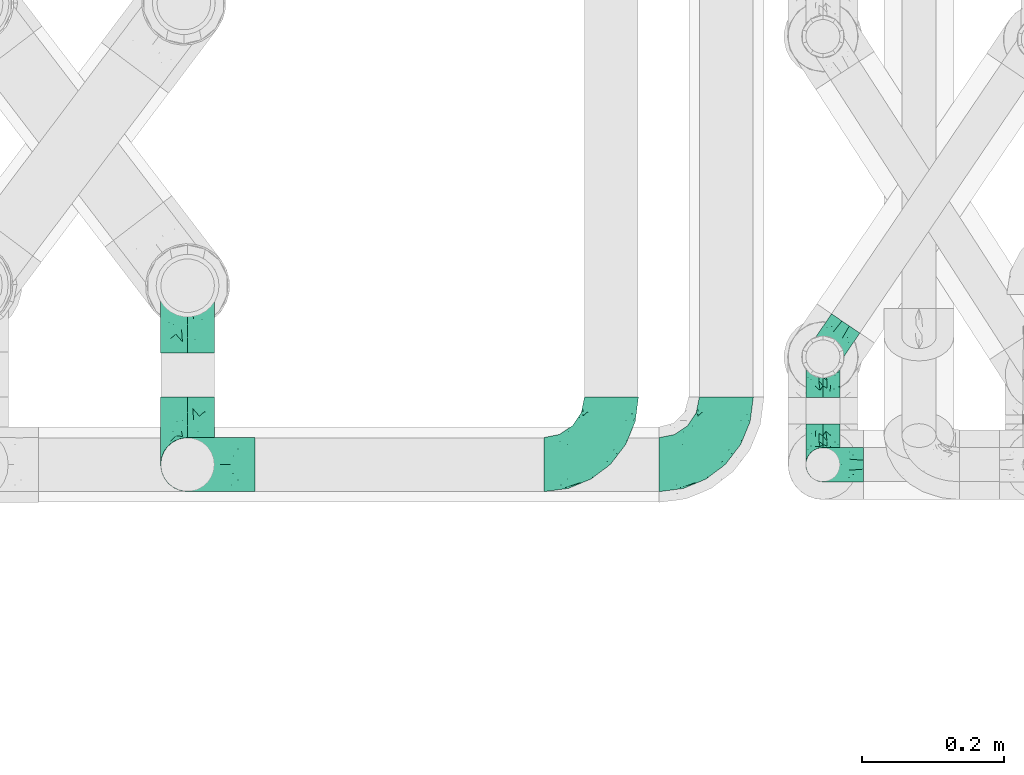
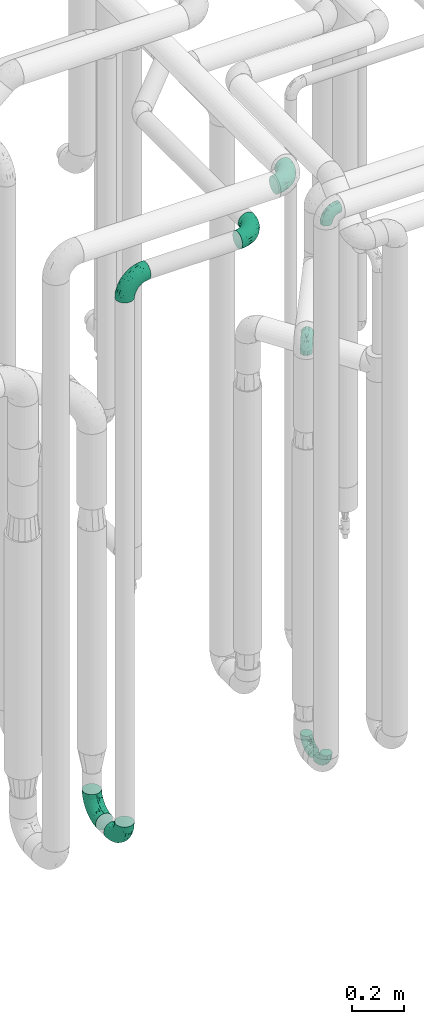
# One storey, part 660 of 827: 9 flow fittings.
"""IFC2X3 building model written with IfcOpenShell, lengths in millimetres."""

from ifc_helpers import new_model, entity, si_unit, converted_unit, derived_unit, direction, frame, origin, place, context, subcontext, project, spatial, faceted_brep, source, transform, mapped, material, type_object, type_shapes, element, save


model = new_model("IFC2X3")

# Units and contexts
model_context = context("Model", 3, precision=0.01, world=origin(), true_north=direction((6.12303176911189e-17, 1.0)))
body_context = subcontext(model_context, "Body", "Model", "MODEL_VIEW")
ifc_project = project(units=[si_unit("LENGTHUNIT", "METRE", prefix="MILLI"), si_unit("AREAUNIT", "SQUARE_METRE"), si_unit("VOLUMEUNIT", "CUBIC_METRE"), converted_unit("PLANEANGLEUNIT", "DEGREE", entity("IfcRatioMeasure", 0.0174532925199433), si_unit("PLANEANGLEUNIT", "RADIAN"), dimensions=[0, 0, 0, 0, 0, 0, 0]), si_unit("MASSUNIT", "GRAM", prefix="KILO"), derived_unit("MASSDENSITYUNIT", [(si_unit("MASSUNIT", "GRAM", prefix="KILO"), 1), (si_unit("LENGTHUNIT", "METRE"), -3)]), derived_unit("MOMENTOFINERTIAUNIT", [(si_unit("LENGTHUNIT", "METRE"), 4)]), si_unit("TIMEUNIT", "SECOND"), si_unit("FREQUENCYUNIT", "HERTZ"), si_unit("THERMODYNAMICTEMPERATUREUNIT", "DEGREE_CELSIUS"), derived_unit("THERMALTRANSMITTANCEUNIT", [(si_unit("MASSUNIT", "GRAM", prefix="KILO"), 1), (si_unit("THERMODYNAMICTEMPERATUREUNIT", "KELVIN"), -1), (si_unit("TIMEUNIT", "SECOND"), -3)]), derived_unit("VOLUMETRICFLOWRATEUNIT", [(si_unit("LENGTHUNIT", "METRE"), 3), (si_unit("TIMEUNIT", "SECOND"), -1)]), derived_unit("MASSFLOWRATEUNIT", [(si_unit("MASSUNIT", "GRAM", prefix="KILO"), 1), (si_unit("TIMEUNIT", "SECOND"), -1)]), derived_unit("ROTATIONALFREQUENCYUNIT", [(si_unit("TIMEUNIT", "SECOND"), -1)]), si_unit("ELECTRICCURRENTUNIT", "AMPERE"), si_unit("ELECTRICVOLTAGEUNIT", "VOLT"), si_unit("POWERUNIT", "WATT"), si_unit("FORCEUNIT", "NEWTON", prefix="KILO"), si_unit("ILLUMINANCEUNIT", "LUX"), si_unit("LUMINOUSFLUXUNIT", "LUMEN"), si_unit("LUMINOUSINTENSITYUNIT", "CANDELA"), derived_unit("USERDEFINED", [(si_unit("MASSUNIT", "GRAM", prefix="KILO"), -1), (si_unit("LENGTHUNIT", "METRE"), -2), (si_unit("TIMEUNIT", "SECOND"), 3), (si_unit("LUMINOUSFLUXUNIT", "LUMEN"), 1)]), derived_unit("LINEARVELOCITYUNIT", [(si_unit("LENGTHUNIT", "METRE"), 1), (si_unit("TIMEUNIT", "SECOND"), -1)]), si_unit("PRESSUREUNIT", "PASCAL"), derived_unit("USERDEFINED", [(si_unit("LENGTHUNIT", "METRE"), -2), (si_unit("MASSUNIT", "GRAM", prefix="KILO"), 1), (si_unit("TIMEUNIT", "SECOND"), -2)]), derived_unit("LINEARFORCEUNIT", [(si_unit("MASSUNIT", "GRAM", prefix="KILO"), 1), (si_unit("LENGTHUNIT", "METRE"), 1), (si_unit("TIMEUNIT", "SECOND"), -2), (si_unit("LENGTHUNIT", "METRE"), -1)]), derived_unit("PLANARFORCEUNIT", [(si_unit("MASSUNIT", "GRAM", prefix="KILO"), 1), (si_unit("LENGTHUNIT", "METRE"), 1), (si_unit("TIMEUNIT", "SECOND"), -2), (si_unit("LENGTHUNIT", "METRE"), -2)])], contexts=[model_context])

# Site, building, storey
site_placement = place(None, origin())
site = spatial("IfcSite", under=ifc_project, at=site_placement, CompositionType="ELEMENT")
building_placement = place(site_placement, origin())
building = spatial("IfcBuilding", under=site, at=building_placement, CompositionType="ELEMENT")
storey_placement = place(building_placement, frame((0.0, 0.0, 28200.0)))
storey = spatial("IfcBuildingStorey", under=building, at=storey_placement, Name="08", CompositionType="ELEMENT", Elevation=28200.0)

# Flow fittings
ifc_material = material()
pipe_fitting_type_1 = type_object("IfcPipeFittingType", Name="ADSK_1", PredefinedType="NOTDEFINED", material=ifc_material)
shared_shape_1 = source(origin(), body_context, "Body", "Brep", [
    faceted_brep([(-57.0, 12.07, -20.91), (-57.0, 6.25, -23.33), (-57.0, 0.0, -24.15), (-57.0, -6.25, -23.33), (-57.0, -12.08, -20.91), (-57.0, -17.08, -17.08), (-57.0, -20.91, -12.08), (-57.0, -23.33, -6.25), (-57.0, -24.15, 0.0), (-57.0, -23.33, 6.25), (-57.0, -20.91, 12.07), (-57.0, -17.08, 17.08), (-57.0, -12.08, 20.91), (-57.0, -6.25, 23.33), (-57.0, 0.0, 24.15), (-57.0, 6.25, 23.33), (-57.0, 12.07, 20.91), (-57.0, 17.08, 17.08), (-57.0, 20.91, 12.07), (-57.0, 23.33, 6.25), (-57.0, 24.15, 0.0), (-57.0, 23.33, -6.25), (-57.0, 20.91, -12.08), (-57.0, 17.08, -17.08), (0.0, 57.0, -24.15), (-6.25, 57.0, -23.33), (-12.07, 57.0, -20.91), (-17.08, 57.0, -17.08), (-20.91, 57.0, -12.08), (-23.33, 57.0, -6.25), (-24.15, 57.0, 0.0), (-23.33, 57.0, 6.25), (-20.91, 57.0, 12.07), (-17.08, 57.0, 17.08), (-12.07, 57.0, 20.91), (-6.25, 57.0, 23.33), (0.0, 57.0, 24.15), (6.25, 57.0, 23.33), (12.08, 57.0, 20.91), (17.08, 57.0, 17.08), (20.91, 57.0, 12.07), (23.33, 57.0, 6.25), (24.15, 57.0, 0.0), (23.33, 57.0, -6.25), (20.91, 57.0, -12.08), (17.08, 57.0, -17.08), (12.08, 57.0, -20.91), (6.25, 57.0, -23.33), (14.9, 21.14, 6.17), (13.61, 24.64, 12.48), (6.23, 8.95, 8.98), (-41.47, -21.06, 0.0), (-41.92, -18.38, 13.72), (-24.64, -13.61, 12.48), (-37.37, -13.24, 18.15), (-6.8, -4.93, 8.18), (-21.76, -15.19, 6.22), (-12.78, -9.18, 0.0), (-37.73, -20.51, 7.75), (-7.38, 7.38, 20.24), (-23.37, -4.26, 20.42), (-11.9, -3.19, 15.86), (-42.14, -8.7, 21.82), (13.24, 37.37, 18.15), (9.33, 23.53, 16.85), (4.26, 23.37, 20.42), (2.77, 10.92, 15.55), (-29.46, 0.91, 23.52), (-44.13, 20.56, 15.69), (-39.25, 26.33, 10.88), (-49.02, 22.92, 9.96), (-34.58, 23.87, 17.15), (-15.8, 6.8, 22.81), (-8.67, 20.47, 23.88), (-18.12, 12.9, 24.08), (-48.29, 14.92, 19.65), (-44.06, -2.85, 23.78), (-9.23, 48.95, 22.58), (-3.78, 42.74, 24.07), (-40.34, 4.26, 24.09), (-44.02, 26.14, 5.46), (-44.04, 9.88, 22.74), (-4.95, 16.87, 22.52), (-2.75, 1.43, 12.5), (-25.48, 40.98, 10.71), (20.51, 37.73, 7.75), (18.38, 41.92, 13.72), (8.7, 42.14, 21.82), (-25.95, -17.97, 0.0), (2.85, 44.06, 23.78), (21.06, 41.47, 0.0), (17.97, 25.95, 0.0), (-24.04, -9.27, 17.13), (-33.26, 33.26, 5.86), (-28.55, 40.57, 0.0), (-40.57, 28.55, 0.0), (-25.29, 47.19, 4.06), (-27.01, 31.1, 16.77), (-15.7, 43.95, 19.9), (-20.27, 45.22, 15.61), (-30.53, 31.98, 12.64), (-11.28, 38.33, 22.92), (-9.97, 27.88, 24.09), (-20.15, 30.26, 21.25), (-31.25, 11.75, 23.64), (-28.75, 7.23, 24.15), (-29.53, 18.06, 22.27), (-28.44, 24.21, 20.02), (-37.55, 17.7, 20.26), (-15.88, 29.25, 22.99), (-20.82, 20.82, 23.44), (-0.91, 29.46, 23.52), (-13.5, -7.67, 12.04), (1.49, 1.56, 5.16), (8.86, 10.35, 4.59), (0.38, -0.38, 0.0), (9.18, 12.78, 0.0), (-37.37, -13.24, -18.15), (8.86, 10.35, -4.59), (-45.22, 20.27, -15.61), (-43.95, 15.7, -19.9), (-38.33, 11.28, -22.92), (-48.95, 9.23, -22.58), (-47.19, 25.29, -4.06), (-33.26, 33.26, -5.86), (18.38, 41.92, -13.72), (-30.26, 20.15, -21.25), (2.85, 44.06, -23.78), (-4.26, 40.34, -24.09), (-40.98, 25.48, -10.71), (-41.92, -18.38, -13.72), (9.25, 23.5, -16.92), (4.26, 23.37, -20.42), (13.24, 37.37, -18.15), (-37.73, -20.51, -7.75), (-11.75, 31.25, -23.64), (-7.23, 28.75, -24.15), (-12.9, 18.12, -24.08), (8.7, 42.14, -21.82), (-44.06, -2.85, -23.78), (-6.8, 15.8, -22.81), (-20.47, 8.67, -23.88), (-24.64, -13.61, -12.48), (-42.74, 3.78, -24.07), (-18.06, 29.53, -22.27), (-24.21, 28.44, -20.02), (-27.88, 9.97, -24.09), (-31.1, 27.01, -16.77), (-26.14, 44.02, -5.46), (14.9, 21.14, -6.17), (20.51, 37.73, -7.75), (-9.88, 44.04, -22.74), (-20.56, 44.13, -15.69), (-21.76, -15.19, -6.22), (-13.5, -7.67, -12.04), (-24.14, -9.76, -16.74), (-11.9, -3.19, -15.86), (-14.92, 48.29, -19.65), (-23.37, -4.26, -20.42), (-0.91, 29.46, -23.52), (-26.33, 39.25, -10.88), (-23.87, 34.58, -17.15), (-42.14, -8.7, -21.82), (-22.92, 49.02, -9.96), (13.61, 24.64, -12.48), (-31.98, 30.53, -12.64), (-16.87, 4.95, -22.52), (-17.7, 37.55, -20.26), (-29.25, 15.88, -22.99), (-20.82, 20.82, -23.44), (-29.46, 0.91, -23.52), (-7.38, 7.38, -20.24), (2.77, 10.92, -15.55), (6.23, 8.95, -8.98), (-6.8, -4.93, -8.18), (-2.81, 1.41, -12.54), (1.49, 1.56, -5.16)], [[[0, 1, 2, 3, 4, 5, 6, 7, 8, 9, 10, 11, 12, 13, 14, 15, 16, 17, 18, 19, 20, 21, 22, 23]], [[24, 25, 26, 27, 28, 29, 30, 31, 32, 33, 34, 35, 36, 37, 38, 39, 40, 41, 42, 43, 44, 45, 46, 47]], [[48, 49, 50]], [[9, 8, 51]], [[52, 53, 54]], [[55, 56, 57]], [[10, 58, 52]], [[9, 58, 10]], [[59, 60, 61]], [[54, 12, 11]], [[54, 62, 12]], [[63, 39, 38]], [[64, 65, 66]], [[62, 60, 67]], [[68, 69, 70]], [[71, 69, 68]], [[72, 73, 74]], [[16, 75, 17]], [[13, 76, 14]], [[35, 77, 78]], [[14, 79, 15]], [[17, 68, 18]], [[14, 76, 79]], [[20, 19, 80]], [[70, 19, 18]], [[81, 15, 79]], [[15, 81, 16]], [[73, 72, 82]], [[66, 83, 50]], [[32, 31, 84]], [[85, 86, 49]], [[63, 87, 65]], [[56, 58, 88]], [[36, 89, 37]], [[85, 41, 40]], [[36, 35, 78]], [[90, 41, 85]], [[40, 39, 86]], [[12, 62, 13]], [[86, 85, 40]], [[48, 85, 49]], [[85, 91, 90]], [[87, 38, 37]], [[92, 60, 54]], [[80, 69, 93]], [[93, 94, 95]], [[10, 52, 11]], [[94, 96, 30]], [[97, 98, 99]], [[80, 93, 95]], [[100, 97, 84]], [[99, 98, 33]], [[101, 102, 78]], [[103, 101, 98]], [[96, 31, 30]], [[77, 98, 101]], [[77, 35, 34]], [[34, 33, 98]], [[9, 51, 58]], [[87, 63, 38]], [[104, 105, 74]], [[106, 103, 107]], [[106, 81, 104]], [[75, 68, 17]], [[108, 107, 71]], [[33, 32, 99]], [[109, 103, 110]], [[101, 109, 102]], [[89, 78, 111]], [[53, 52, 58]], [[54, 11, 52]], [[60, 62, 54]], [[88, 58, 51]], [[76, 62, 67]], [[53, 112, 92]], [[60, 59, 72]], [[39, 63, 86]], [[49, 86, 63]], [[89, 87, 37]], [[42, 41, 90]], [[111, 82, 65]], [[111, 65, 87]], [[65, 59, 66]], [[104, 81, 79]], [[75, 81, 108]], [[32, 84, 99]], [[97, 99, 84]], [[98, 97, 103]], [[106, 107, 108]], [[74, 102, 110]], [[111, 78, 102]], [[74, 110, 104]], [[74, 67, 72]], [[61, 92, 112]], [[66, 59, 61]], [[56, 53, 58]], [[66, 50, 49]], [[61, 112, 83]], [[66, 49, 64]], [[78, 89, 36]], [[87, 89, 111]], [[62, 76, 13]], [[79, 76, 67]], [[100, 93, 69]], [[96, 93, 84]], [[55, 113, 50]], [[113, 114, 50]], [[104, 79, 105]], [[106, 104, 110]], [[20, 80, 95]], [[85, 48, 91]], [[115, 114, 113]], [[116, 91, 48]], [[70, 80, 19]], [[93, 96, 94]], [[84, 31, 96]], [[103, 106, 110]], [[81, 106, 108]], [[103, 97, 107]], [[71, 107, 97]], [[71, 97, 100]], [[108, 71, 68]], [[79, 67, 105]], [[67, 74, 105]], [[115, 113, 57]], [[112, 56, 55]], [[56, 88, 57]], [[60, 72, 67]], [[82, 72, 59]], [[65, 82, 59]], [[82, 111, 73]], [[111, 102, 73]], [[102, 74, 73]], [[81, 75, 16]], [[68, 75, 108]], [[68, 70, 18]], [[80, 70, 69]], [[98, 77, 34]], [[78, 77, 101]], [[93, 100, 84]], [[71, 100, 69]], [[102, 109, 110]], [[101, 103, 109]], [[53, 92, 54]], [[61, 60, 92]], [[56, 112, 53]], [[83, 112, 55]], [[50, 83, 55]], [[61, 83, 66]], [[49, 63, 64]], [[65, 64, 63]], [[57, 113, 55]], [[114, 115, 116]], [[116, 48, 114]], [[48, 50, 114]], [[117, 5, 4]], [[116, 115, 118]], [[119, 120, 23]], [[121, 122, 120]], [[95, 123, 20]], [[0, 23, 120]], [[124, 95, 94]], [[125, 45, 44]], [[121, 120, 126]], [[24, 127, 128]], [[22, 21, 129]], [[0, 122, 1]], [[5, 117, 130]], [[131, 132, 133]], [[134, 88, 51]], [[135, 136, 137]], [[6, 5, 130]], [[46, 138, 47]], [[139, 3, 2]], [[140, 141, 137]], [[6, 134, 7]], [[134, 130, 142]], [[143, 2, 1]], [[144, 126, 145]], [[121, 146, 143]], [[147, 120, 119]], [[94, 148, 124]], [[149, 150, 91]], [[30, 29, 148]], [[151, 25, 128]], [[27, 152, 28]], [[134, 153, 88]], [[154, 155, 156]], [[27, 26, 157]], [[151, 26, 25]], [[155, 158, 156]], [[24, 47, 127]], [[1, 122, 143]], [[138, 132, 159]], [[160, 152, 161]], [[24, 128, 25]], [[46, 133, 138]], [[162, 117, 4]], [[148, 160, 124]], [[152, 160, 163]], [[154, 142, 155]], [[45, 125, 133]], [[133, 46, 45]], [[125, 164, 133]], [[51, 7, 134]], [[42, 90, 43]], [[165, 147, 129]], [[153, 134, 142]], [[43, 150, 44]], [[162, 4, 3]], [[141, 140, 166]], [[117, 162, 158]], [[163, 29, 28]], [[43, 90, 150]], [[123, 21, 20]], [[144, 151, 135]], [[157, 152, 27]], [[167, 145, 161]], [[23, 22, 119]], [[168, 126, 169]], [[121, 168, 146]], [[139, 143, 170]], [[142, 130, 117]], [[8, 7, 51]], [[134, 6, 130]], [[139, 162, 3]], [[170, 166, 158]], [[170, 158, 162]], [[158, 171, 156]], [[44, 150, 125]], [[91, 150, 90]], [[164, 125, 150]], [[132, 138, 133]], [[127, 138, 159]], [[131, 164, 172]], [[132, 171, 140]], [[135, 151, 128]], [[157, 151, 167]], [[22, 129, 119]], [[147, 119, 129]], [[120, 147, 126]], [[144, 145, 167]], [[137, 146, 169]], [[170, 143, 146]], [[137, 169, 135]], [[137, 159, 140]], [[171, 172, 156]], [[173, 174, 175]], [[156, 175, 154]], [[174, 57, 153]], [[132, 172, 171]], [[172, 164, 173]], [[143, 139, 2]], [[162, 139, 170]], [[138, 127, 47]], [[128, 127, 159]], [[165, 124, 160]], [[123, 124, 129]], [[149, 173, 164]], [[176, 174, 173]], [[135, 128, 136]], [[144, 135, 169]], [[150, 149, 164]], [[176, 118, 115]], [[149, 91, 116]], [[30, 148, 94]], [[163, 148, 29]], [[124, 123, 95]], [[129, 21, 123]], [[126, 144, 169]], [[151, 144, 167]], [[126, 147, 145]], [[161, 145, 147]], [[161, 147, 165]], [[167, 161, 152]], [[128, 159, 136]], [[159, 137, 136]], [[154, 153, 142]], [[132, 140, 159]], [[174, 176, 57]], [[57, 88, 153]], [[166, 140, 171]], [[158, 166, 171]], [[166, 170, 141]], [[170, 146, 141]], [[146, 137, 141]], [[151, 157, 26]], [[152, 157, 167]], [[152, 163, 28]], [[148, 163, 160]], [[120, 122, 0]], [[143, 122, 121]], [[124, 165, 129]], [[161, 165, 160]], [[146, 168, 169]], [[121, 126, 168]], [[142, 117, 155]], [[158, 155, 117]], [[175, 156, 172]], [[153, 154, 174]], [[173, 175, 172]], [[174, 154, 175]], [[164, 131, 133]], [[172, 132, 131]], [[176, 173, 118]], [[57, 176, 115]], [[173, 149, 118]], [[149, 116, 118]]]),
])
type_shapes(pipe_fitting_type_1, [shared_shape_1])
for number, where, z_axis, x_axis, name in (
    (1, (46692.79, 13788.51, 400.0), (1.0, 0.0, 0.0), (0.0, 1.0, 0.0), "ADSK_1"),
    (2, (46692.79, 13636.84, 3000.0), (0.0, -1.0, 0.0), (-1.0, 0.0, 0.0), "ADSK_1"),
    (3, (46692.79, 13636.84, 400.0), (-1.0, 0.0, 0.0), (0.0, -1.0, 0.0), "ADSK_1"),
    (4, (46692.79, 13788.51, 2300.0), (-0.827641016663895, 0.561257826257732, 0.0), (0.0, 0.0, 1.0), "ADSK_1"),
):
    element("IfcFlowFitting", number, at=place(storey_placement, frame(where, z_axis=z_axis, x_axis=x_axis)), inside=storey, type_object=pipe_fitting_type_1, material=ifc_material, Name=name, ObjectType="ADSK_1", context=body_context, shape_type="MappedRepresentation", body=[
        mapped(shared_shape_1, transform((0.0, 0.0, 0.0), scale=1.0)),
    ])
pipe_fitting_type_2 = type_object("IfcPipeFittingType", Name="ADSK_1", PredefinedType="NOTDEFINED", material=ifc_material)
shared_shape_2 = source(origin(), body_context, "Body", "Brep", [
    faceted_brep([(-95.0, 19.02, -32.95), (-95.0, 9.85, -36.75), (-95.0, 0.0, -38.05), (-95.0, -9.85, -36.75), (-95.0, -19.03, -32.95), (-95.0, -26.91, -26.91), (-95.0, -32.95, -19.03), (-95.0, -36.75, -9.85), (-95.0, -38.05, 0.0), (-95.0, -36.75, 9.85), (-95.0, -32.95, 19.02), (-95.0, -26.91, 26.91), (-95.0, -19.03, 32.95), (-95.0, -9.85, 36.75), (-95.0, 0.0, 38.05), (-95.0, 9.85, 36.75), (-95.0, 19.02, 32.95), (-95.0, 26.91, 26.91), (-95.0, 32.95, 19.02), (-95.0, 36.75, 9.85), (-95.0, 38.05, 0.0), (-95.0, 36.75, -9.85), (-95.0, 32.95, -19.03), (-95.0, 26.91, -26.91), (0.0, 95.0, -38.05), (-9.85, 95.0, -36.75), (-19.02, 95.0, -32.95), (-26.91, 95.0, -26.91), (-32.95, 95.0, -19.03), (-36.75, 95.0, -9.85), (-38.05, 95.0, 0.0), (-36.75, 95.0, 9.85), (-32.95, 95.0, 19.02), (-26.91, 95.0, 26.91), (-19.02, 95.0, 32.95), (-9.85, 95.0, 36.75), (0.0, 95.0, 38.05), (9.85, 95.0, 36.75), (19.03, 95.0, 32.95), (26.91, 95.0, 26.91), (32.95, 95.0, 19.02), (36.75, 95.0, 9.85), (38.05, 95.0, 0.0), (36.75, 95.0, -9.85), (32.95, 95.0, -19.03), (26.91, 95.0, -26.91), (19.03, 95.0, -32.95), (9.85, 95.0, -36.75), (-7.99, -4.96, 6.3), (-0.92, 0.92, 0.0), (4.62, 8.1, 8.01), (-76.19, -35.57, 0.0), (-64.32, -32.32, 12.43), (20.51, 62.45, 28.68), (-60.56, -33.52, 0.0), (-70.4, -13.47, 34.42), (-39.61, -5.88, 32.32), (-49.6, 2.07, 37.1), (-70.34, -28.81, 21.71), (14.64, 40.81, 26.5), (5.88, 39.61, 32.32), (3.59, 20.77, 25.31), (-40.45, 68.06, 16.75), (-62.45, -20.51, 28.68), (-44.52, -26.87, 0.0), (-28.47, -20.22, 0.0), (-26.43, -17.83, 8.75), (-76.1, 39.63, 10.76), (-72.74, 37.58, 18.19), (-60.35, 46.18, 14.61), (-13.4, 13.4, 32.12), (-20.77, -3.59, 25.31), (-14.66, 81.47, 35.56), (-6.22, 71.26, 37.92), (-57.5, 42.48, 22.79), (-15.0, 34.74, 37.7), (-27.1, 12.08, 36.05), (-9.2, 28.81, 35.63), (-79.98, 23.7, 30.95), (-73.68, -4.3, 37.48), (-30.74, 21.67, 37.97), (-62.36, 47.59, 6.79), (-72.71, 32.83, 24.69), (-67.42, 7.02, 37.95), (-32.13, 75.27, 24.51), (-43.46, 51.47, 26.26), (-24.98, 73.15, 31.29), (20.59, 41.28, 19.85), (7.79, 16.09, 15.86), (-73.21, 42.39, 0.0), (-54.73, 54.73, 0.0), (-73.44, 15.79, 35.79), (-5.94, 4.32, 20.43), (28.81, 70.34, 21.71), (32.32, 64.32, 12.43), (-53.59, 26.2, 35.09), (-52.02, 19.31, 37.21), (21.38, 33.53, 10.34), (26.87, 44.52, 0.0), (-48.28, 12.14, 38.05), (4.3, 73.68, 37.48), (-44.08, -25.52, 12.79), (-41.28, -20.59, 19.85), (35.57, 76.19, 0.0), (-47.26, 54.3, 20.18), (-47.4, 61.99, 8.58), (-42.39, 73.21, 0.0), (-39.67, 78.86, 7.21), (-45.69, 36.84, 33.11), (-32.83, 50.13, 33.35), (13.47, 70.4, 34.42), (-18.25, 63.73, 36.07), (-40.63, -13.75, 27.22), (-16.63, 46.37, 37.95), (-53.47, 38.79, 28.59), (-26.07, 48.54, 36.15), (-34.51, 34.51, 36.86), (-2.07, 49.6, 37.1), (-22.79, -10.49, 19.23), (-61.73, 28.67, 31.87), (9.65, 14.7, 0.0), (20.22, 28.47, 0.0), (33.52, 60.56, 0.0), (-11.42, -5.44, 13.25), (-14.7, -9.65, 0.0), (-81.47, 14.66, -35.56), (-62.45, -20.51, -28.68), (-71.26, 6.22, -37.92), (-75.27, 32.13, -24.51), (-73.15, 24.98, -31.29), (13.47, 70.4, -34.42), (5.88, 39.61, -32.32), (-2.07, 49.6, -37.1), (-78.86, 39.67, -7.21), (-70.4, -13.47, -34.42), (-39.61, -5.88, -32.32), (-61.99, 47.4, -8.58), (32.32, 64.32, -12.43), (28.81, 70.34, -21.71), (-63.73, 18.25, -36.07), (-50.13, 32.83, -33.35), (4.3, 73.68, -37.48), (-7.02, 67.42, -37.95), (-39.63, 76.1, -10.76), (-46.18, 60.35, -14.61), (-47.59, 62.36, -6.79), (-64.32, -32.32, -12.43), (-26.2, 53.59, -35.09), (-15.79, 73.44, -35.79), (-19.31, 52.02, -37.21), (-37.58, 72.74, -18.19), (-70.34, -28.81, -21.71), (-42.48, 57.5, -22.79), (-38.79, 53.47, -28.59), (-51.47, 43.46, -26.26), (-32.83, 72.71, -24.69), (-46.37, 16.63, -37.95), (-73.68, -4.3, -37.48), (-41.28, -20.59, -19.85), (-44.08, -25.52, -12.79), (13.75, 40.63, -27.22), (20.51, 62.45, -28.68), (-68.06, 40.45, -16.75), (-54.3, 47.26, -20.18), (-12.14, 48.28, -38.05), (-21.67, 30.74, -37.97), (-36.84, 45.69, -33.11), (-11.42, -5.44, -13.25), (7.79, 16.09, -15.86), (4.62, 8.1, -8.01), (-23.7, 79.98, -30.95), (-26.43, -17.83, -8.75), (-7.99, -4.96, -6.3), (-40.81, -14.64, -26.5), (-20.77, -3.59, -25.31), (-34.74, 15.0, -37.7), (-12.08, 27.1, -36.05), (-28.81, 9.2, -35.63), (-22.79, -10.49, -19.23), (21.38, 33.53, -10.34), (20.59, 41.28, -19.85), (-48.54, 26.07, -36.15), (-49.6, 2.07, -37.1), (-13.4, 13.4, -32.12), (3.59, 20.77, -25.31), (-28.67, 61.73, -31.87), (-34.51, 34.51, -36.86), (-5.94, 4.32, -20.43)], [[[0, 1, 2, 3, 4, 5, 6, 7, 8, 9, 10, 11, 12, 13, 14, 15, 16, 17, 18, 19, 20, 21, 22, 23]], [[24, 25, 26, 27, 28, 29, 30, 31, 32, 33, 34, 35, 36, 37, 38, 39, 40, 41, 42, 43, 44, 45, 46, 47]], [[48, 49, 50]], [[51, 52, 9]], [[53, 39, 38]], [[9, 52, 10]], [[54, 52, 51]], [[55, 56, 57]], [[11, 10, 58]], [[59, 60, 61]], [[32, 31, 62]], [[63, 12, 11]], [[63, 55, 12]], [[64, 65, 66]], [[67, 68, 69]], [[70, 56, 71]], [[35, 72, 73]], [[69, 68, 74]], [[75, 76, 77]], [[16, 78, 17]], [[13, 79, 14]], [[76, 75, 80]], [[67, 69, 81]], [[18, 17, 82]], [[14, 79, 83]], [[20, 19, 67]], [[84, 85, 86]], [[87, 61, 88]], [[89, 81, 90]], [[18, 82, 68]], [[15, 91, 16]], [[14, 83, 15]], [[71, 92, 61]], [[17, 78, 82]], [[93, 87, 94]], [[95, 91, 96]], [[97, 98, 94]], [[86, 72, 34]], [[96, 99, 80]], [[37, 36, 100]], [[40, 39, 93]], [[40, 94, 41]], [[64, 66, 101]], [[93, 94, 40]], [[58, 102, 63]], [[94, 103, 41]], [[94, 87, 97]], [[104, 69, 74]], [[34, 33, 86]], [[105, 69, 104]], [[52, 58, 10]], [[106, 107, 30]], [[108, 109, 85]], [[105, 106, 90]], [[53, 110, 60]], [[86, 111, 72]], [[86, 109, 111]], [[33, 84, 86]], [[12, 55, 13]], [[112, 56, 63]], [[110, 38, 37]], [[34, 72, 35]], [[36, 35, 73]], [[111, 113, 73]], [[105, 107, 106]], [[110, 53, 38]], [[74, 114, 85]], [[91, 15, 83]], [[105, 90, 81]], [[107, 62, 31]], [[33, 32, 84]], [[115, 109, 116]], [[111, 115, 113]], [[100, 73, 117]], [[56, 55, 63]], [[79, 55, 57]], [[102, 118, 112]], [[56, 70, 76]], [[100, 110, 37]], [[117, 77, 60]], [[117, 60, 110]], [[60, 70, 61]], [[58, 52, 101]], [[63, 11, 58]], [[39, 53, 93]], [[87, 93, 53]], [[96, 91, 83]], [[78, 91, 119]], [[32, 62, 84]], [[84, 62, 104]], [[86, 85, 109]], [[85, 114, 108]], [[80, 113, 116]], [[117, 73, 113]], [[80, 116, 96]], [[80, 57, 76]], [[71, 112, 118]], [[61, 87, 59]], [[62, 107, 105]], [[97, 120, 121]], [[70, 71, 61]], [[71, 118, 92]], [[73, 100, 36]], [[110, 100, 117]], [[55, 79, 13]], [[83, 79, 57]], [[96, 83, 99]], [[116, 108, 95]], [[50, 97, 88]], [[97, 87, 88]], [[50, 49, 120]], [[122, 94, 98]], [[89, 20, 67]], [[105, 81, 69]], [[89, 67, 81]], [[68, 19, 18]], [[68, 67, 19]], [[74, 68, 82]], [[114, 82, 119]], [[74, 85, 104]], [[82, 114, 74]], [[114, 119, 108]], [[95, 108, 119]], [[116, 109, 108]], [[123, 48, 50]], [[97, 50, 120]], [[123, 50, 88]], [[91, 95, 119]], [[116, 95, 96]], [[84, 104, 85]], [[104, 62, 105]], [[83, 57, 99]], [[57, 80, 99]], [[66, 48, 123]], [[66, 124, 48]], [[118, 66, 123]], [[124, 66, 65]], [[66, 118, 101]], [[54, 64, 52]], [[124, 49, 48]], [[30, 107, 31]], [[91, 78, 16]], [[82, 78, 119]], [[56, 76, 57]], [[77, 76, 70]], [[60, 77, 70]], [[77, 117, 75]], [[117, 113, 75]], [[113, 80, 75]], [[9, 8, 51]], [[103, 94, 122]], [[103, 42, 41]], [[73, 72, 111]], [[113, 115, 116]], [[111, 109, 115]], [[102, 112, 63]], [[71, 56, 112]], [[118, 102, 101]], [[92, 123, 88]], [[123, 92, 118]], [[61, 92, 88]], [[87, 53, 59]], [[60, 59, 53]], [[97, 121, 98]], [[58, 101, 102]], [[64, 101, 52]], [[125, 1, 0]], [[126, 5, 4]], [[2, 1, 127]], [[1, 125, 127]], [[128, 129, 23]], [[130, 131, 132]], [[89, 133, 20]], [[126, 134, 135]], [[136, 89, 90]], [[137, 138, 44]], [[139, 129, 140]], [[24, 141, 142]], [[143, 144, 145]], [[125, 129, 139]], [[6, 146, 7]], [[147, 148, 149]], [[146, 51, 7]], [[143, 150, 144]], [[146, 6, 151]], [[152, 153, 154]], [[126, 4, 134]], [[0, 23, 129]], [[28, 155, 150]], [[43, 42, 103]], [[54, 146, 64]], [[139, 156, 127]], [[157, 3, 2]], [[151, 158, 159]], [[160, 131, 161]], [[22, 21, 162]], [[136, 144, 163]], [[149, 164, 165]], [[24, 142, 25]], [[166, 140, 154]], [[154, 129, 128]], [[143, 30, 29]], [[167, 168, 169]], [[155, 28, 27]], [[26, 170, 27]], [[171, 167, 172]], [[26, 25, 148]], [[27, 170, 155]], [[173, 135, 174]], [[144, 150, 152]], [[175, 176, 177]], [[24, 47, 141]], [[45, 161, 46]], [[148, 25, 142]], [[176, 175, 165]], [[64, 159, 171]], [[138, 45, 44]], [[130, 46, 161]], [[137, 44, 43]], [[178, 159, 158]], [[137, 103, 122]], [[163, 144, 152]], [[136, 133, 89]], [[103, 137, 43]], [[6, 5, 151]], [[178, 158, 173]], [[134, 4, 3]], [[178, 173, 174]], [[137, 98, 179]], [[145, 90, 106]], [[138, 180, 161]], [[46, 130, 47]], [[136, 90, 145]], [[133, 162, 21]], [[23, 22, 128]], [[139, 140, 181]], [[139, 181, 156]], [[157, 127, 182]], [[157, 134, 3]], [[182, 177, 135]], [[182, 135, 134]], [[135, 183, 174]], [[131, 130, 161]], [[141, 130, 132]], [[160, 180, 184]], [[131, 183, 176]], [[5, 126, 151]], [[158, 151, 126]], [[180, 138, 137]], [[161, 45, 138]], [[149, 148, 142]], [[170, 148, 185]], [[22, 162, 128]], [[128, 162, 163]], [[129, 154, 140]], [[154, 153, 166]], [[165, 156, 186]], [[182, 127, 156]], [[165, 186, 149]], [[165, 132, 176]], [[131, 184, 183]], [[187, 167, 178]], [[184, 168, 187]], [[167, 169, 172]], [[184, 180, 168]], [[174, 183, 184]], [[127, 157, 2]], [[134, 157, 182]], [[130, 141, 47]], [[142, 141, 132]], [[149, 142, 164]], [[186, 166, 147]], [[180, 179, 168]], [[169, 179, 120]], [[137, 179, 180]], [[179, 121, 120]], [[106, 30, 143]], [[136, 145, 144]], [[106, 143, 145]], [[150, 29, 28]], [[150, 143, 29]], [[152, 150, 155]], [[153, 155, 185]], [[152, 154, 163]], [[155, 153, 152]], [[153, 185, 166]], [[147, 166, 185]], [[186, 140, 166]], [[169, 120, 49]], [[169, 49, 172]], [[179, 169, 168]], [[148, 147, 185]], [[186, 147, 149]], [[128, 163, 154]], [[163, 162, 136]], [[142, 132, 164]], [[132, 165, 164]], [[171, 124, 65]], [[124, 171, 172]], [[64, 146, 159]], [[171, 159, 178]], [[171, 65, 64]], [[172, 49, 124]], [[162, 133, 136]], [[20, 133, 21]], [[148, 170, 26]], [[155, 170, 185]], [[131, 176, 132]], [[177, 176, 183]], [[135, 177, 183]], [[177, 182, 175]], [[182, 156, 175]], [[156, 165, 175]], [[51, 146, 54]], [[51, 8, 7]], [[129, 125, 0]], [[127, 125, 139]], [[140, 186, 181]], [[156, 181, 186]], [[158, 126, 173]], [[135, 173, 126]], [[187, 178, 174]], [[171, 178, 167]], [[184, 187, 174]], [[167, 187, 168]], [[180, 160, 161]], [[184, 131, 160]], [[98, 137, 122]], [[98, 121, 179]], [[151, 159, 146]]]),
])
type_shapes(pipe_fitting_type_2, [shared_shape_2])
for number, where, z_axis, x_axis, name in (
    (5, (45798.44, 13636.98, 350.0), (1.0, 0.0, 0.0), (0.0, 0.0, -1.0), "ADSK_1"),
    (6, (45798.44, 13888.82, 350.0), (1.0, 0.0, 0.0), (0.0, 1.0, 0.0), "ADSK_1"),
    (7, (45798.44, 13636.98, 3000.0), (0.0, 1.0, 0.0), (0.0, 0.0, 1.0), "ADSK_1"),
):
    element("IfcFlowFitting", number, at=place(storey_placement, frame(where, z_axis=z_axis, x_axis=x_axis)), inside=storey, type_object=pipe_fitting_type_2, material=ifc_material, Name=name, ObjectType="ADSK_1", context=body_context, shape_type="MappedRepresentation", body=[
        mapped(shared_shape_2, transform((0.0, 0.0, 0.0), scale=1.0)),
    ])
for number, where, name in (
    (8, (46395.03, 13636.98, 3000.0), "ADSK_1"),
    (9, (46556.77, 13636.84, 3200.05), "ADSK_1"),
):
    element("IfcFlowFitting", number, at=place(storey_placement, frame(where)), inside=storey, type_object=pipe_fitting_type_2, material=ifc_material, Name=name, ObjectType="ADSK_1", context=body_context, shape_type="MappedRepresentation", body=[
        mapped(shared_shape_2, transform((0.0, 0.0, 0.0), scale=1.0)),
    ])

save(model, "model.ifc")
